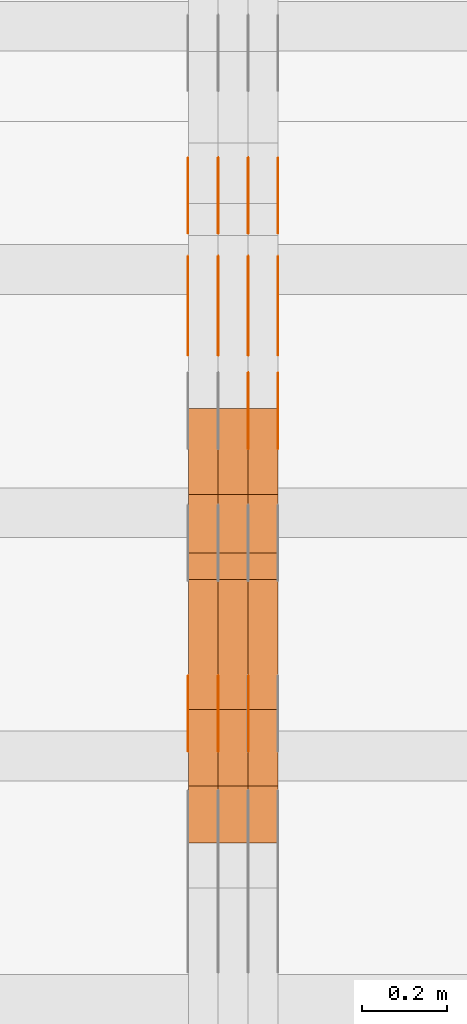
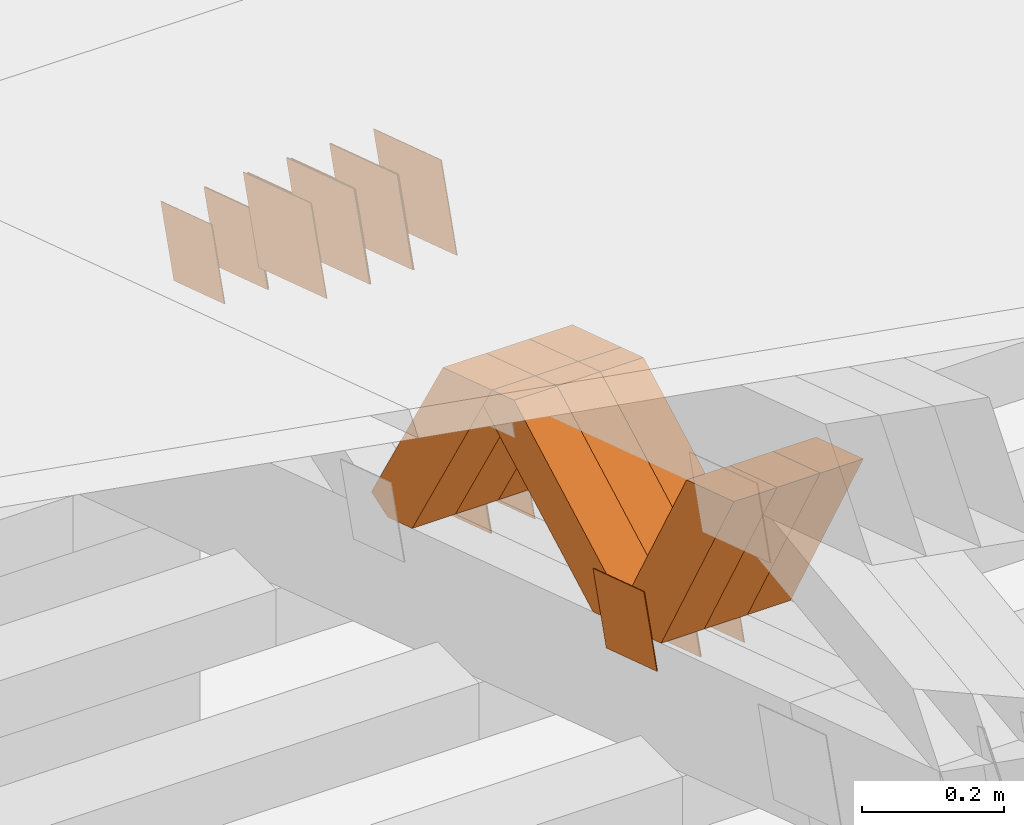
# One storey, part 194 of 385: 28 proxies.
"""IFC2X3 building model written with IfcOpenShell, lengths in millimetres."""

from ifc_helpers import new_model, entity, si_unit, converted_unit, derived_unit, direction, frame, origin, place, context, subcontext, project, spatial, polyline, outline, extrude, source, transform, mapped, material, type_object, type_shapes, element, save


model = new_model("IFC2X3")

# Units and contexts
model_context = context("Model", 3, precision=0.01, world=origin(), true_north=direction((6.12303176911189e-17, 1.0)))
body_context = subcontext(model_context, "Body", "Model", "MODEL_VIEW")
ifc_project = project(units=[si_unit("LENGTHUNIT", "METRE", prefix="MILLI"), si_unit("AREAUNIT", "SQUARE_METRE"), si_unit("VOLUMEUNIT", "CUBIC_METRE"), converted_unit("PLANEANGLEUNIT", "DEGREE", entity("IfcRatioMeasure", 0.0174532925199433), si_unit("PLANEANGLEUNIT", "RADIAN"), dimensions=[0, 0, 0, 0, 0, 0, 0]), si_unit("MASSUNIT", "GRAM", prefix="KILO"), derived_unit("MASSDENSITYUNIT", [(si_unit("MASSUNIT", "GRAM", prefix="KILO"), 1), (si_unit("LENGTHUNIT", "METRE"), -3)]), si_unit("TIMEUNIT", "SECOND"), si_unit("FREQUENCYUNIT", "HERTZ"), si_unit("THERMODYNAMICTEMPERATUREUNIT", "DEGREE_CELSIUS"), derived_unit("THERMALTRANSMITTANCEUNIT", [(si_unit("MASSUNIT", "GRAM", prefix="KILO"), 1), (si_unit("THERMODYNAMICTEMPERATUREUNIT", "KELVIN"), -1), (si_unit("TIMEUNIT", "SECOND"), -3)]), derived_unit("VOLUMETRICFLOWRATEUNIT", [(si_unit("LENGTHUNIT", "METRE"), 3), (si_unit("TIMEUNIT", "SECOND"), -1)]), si_unit("ELECTRICCURRENTUNIT", "AMPERE"), si_unit("ELECTRICVOLTAGEUNIT", "VOLT"), si_unit("POWERUNIT", "WATT"), si_unit("FORCEUNIT", "NEWTON", prefix="KILO"), si_unit("ILLUMINANCEUNIT", "LUX"), si_unit("LUMINOUSFLUXUNIT", "LUMEN"), si_unit("LUMINOUSINTENSITYUNIT", "CANDELA"), derived_unit("USERDEFINED", [(si_unit("MASSUNIT", "GRAM", prefix="KILO"), -1), (si_unit("LENGTHUNIT", "METRE"), -2), (si_unit("TIMEUNIT", "SECOND"), 3), (si_unit("LUMINOUSFLUXUNIT", "LUMEN"), 1)]), derived_unit("LINEARVELOCITYUNIT", [(si_unit("LENGTHUNIT", "METRE"), 1), (si_unit("TIMEUNIT", "SECOND"), -1)]), si_unit("PRESSUREUNIT", "PASCAL"), derived_unit("USERDEFINED", [(si_unit("LENGTHUNIT", "METRE"), -2), (si_unit("MASSUNIT", "GRAM", prefix="KILO"), 1), (si_unit("TIMEUNIT", "SECOND"), -2)])], contexts=[model_context])

# Site, building, storey
site_placement = place(None, origin())
site = spatial("IfcSite", under=ifc_project, at=site_placement, CompositionType="ELEMENT")
building_placement = place(site_placement, origin())
building = spatial("IfcBuilding", under=site, at=building_placement, CompositionType="ELEMENT")
storey_placement = place(building_placement, origin())
storey = spatial("IfcBuildingStorey", under=building, at=storey_placement, Name="Default", CompositionType="ELEMENT", Elevation=0.0)

# Proxies
ifc_material_1 = material(Name="IfcSurfaceStyle #177786")
building_element_proxy_type_1 = type_object("IfcBuildingElementProxyType", PredefinedType="NOTDEFINED", material=ifc_material_1)
shared_shape_1 = source(origin(), body_context, "Body", "SweptSolid", [
    extrude(outline(polyline([(-74.9998605591059, -59.9999264677526), (74.999875428623, -59.9999264677526), (74.9998605591068, 59.9999264677526), (-74.9998754286239, 59.9999264677526), (-74.9998605591059, -59.9999264677526)])), frame((75.0000889884782, 60.0000460315623, 0.0), z_axis=(0.0, 0.0, 1.0), x_axis=(-1.0, 0.0, 0.0)), (0.0, 0.0, 1.0), 1.3),
])
type_shapes(building_element_proxy_type_1, [shared_shape_1])
proxy_1_placement = place(building_placement, frame((12386.3, 20621.9679769682, 2241.76551219004), z_axis=(-1.0, 0.0, 0.0), x_axis=(0.0, -0.951056516295154, 0.309016994374948)))
element("IfcBuildingElementProxy", 1, at=proxy_1_placement, inside=storey, type_object=building_element_proxy_type_1, material=ifc_material_1, context=body_context, shape_type="MappedRepresentation", body=[
    mapped(shared_shape_1, transform((0.0, 0.0, 0.0), scale=1.0)),
])
ifc_material_2 = material(Name="IfcSurfaceStyle #177729")
building_element_proxy_type_2 = type_object("IfcBuildingElementProxyType", PredefinedType="NOTDEFINED", material=ifc_material_2)
shared_shape_2 = source(origin(), body_context, "Body", "SweptSolid", [
    extrude(outline(polyline([(-74.9998605591059, -59.9999264677526), (74.999875428623, -59.9999264677526), (74.9998605591068, 59.9999264677526), (-74.9998754286239, 59.9999264677526), (-74.9998605591059, -59.9999264677526)])), frame((75.0000889884782, 60.0000460315623, 0.0), z_axis=(0.0, 0.0, 1.0), x_axis=(-1.0, 0.0, 0.0)), (0.0, 0.0, 1.0), 1.3),
])
type_shapes(building_element_proxy_type_2, [shared_shape_2])
proxy_2_placement = place(building_placement, frame((12315.0, 20621.9679769682, 2241.76551219004), z_axis=(-1.0, 0.0, 0.0), x_axis=(0.0, -0.951056516295154, 0.309016994374948)))
element("IfcBuildingElementProxy", 2, at=proxy_2_placement, inside=storey, type_object=building_element_proxy_type_2, material=ifc_material_2, context=body_context, shape_type="MappedRepresentation", body=[
    mapped(shared_shape_2, transform((0.0, 0.0, 0.0), scale=1.0)),
])
ifc_material_3 = material(Name="IfcSurfaceStyle #177672")
building_element_proxy_type_3 = type_object("IfcBuildingElementProxyType", PredefinedType="NOTDEFINED", material=ifc_material_3)
shared_shape_3 = source(origin(), body_context, "Body", "SweptSolid", [
    extrude(outline(polyline([(-74.9998605591059, -59.9999264677526), (74.999875428623, -59.9999264677526), (74.9998605591068, 59.9999264677526), (-74.9998754286239, 59.9999264677526), (-74.9998605591059, -59.9999264677526)])), frame((75.0000889884782, 60.0000460315623, 0.0), z_axis=(0.0, 0.0, 1.0), x_axis=(-1.0, 0.0, 0.0)), (0.0, 0.0, 1.0), 1.3),
])
type_shapes(building_element_proxy_type_3, [shared_shape_3])
proxy_3_placement = place(building_placement, frame((12316.3, 20621.9679769682, 2241.76551219004), z_axis=(-1.0, 0.0, 0.0), x_axis=(0.0, -0.951056516295154, 0.309016994374948)))
element("IfcBuildingElementProxy", 3, at=proxy_3_placement, inside=storey, type_object=building_element_proxy_type_3, material=ifc_material_3, context=body_context, shape_type="MappedRepresentation", body=[
    mapped(shared_shape_3, transform((0.0, 0.0, 0.0), scale=1.0)),
])
ifc_material_4 = material(Name="IfcSurfaceStyle #177615")
building_element_proxy_type_4 = type_object("IfcBuildingElementProxyType", PredefinedType="NOTDEFINED", material=ifc_material_4)
shared_shape_4 = source(origin(), body_context, "Body", "SweptSolid", [
    extrude(outline(polyline([(-74.9998605591059, -59.9999264677526), (74.999875428623, -59.9999264677526), (74.9998605591068, 59.9999264677526), (-74.9998754286239, 59.9999264677526), (-74.9998605591059, -59.9999264677526)])), frame((75.0000889884782, 60.0000460315623, 0.0), z_axis=(0.0, 0.0, 1.0), x_axis=(-1.0, 0.0, 0.0)), (0.0, 0.0, 1.0), 1.29999999999999),
])
type_shapes(building_element_proxy_type_4, [shared_shape_4])
proxy_4_placement = place(building_placement, frame((12245.0, 20621.9679769682, 2241.76551219004), z_axis=(-1.0, 0.0, 0.0), x_axis=(0.0, -0.951056516295154, 0.309016994374948)))
element("IfcBuildingElementProxy", 4, at=proxy_4_placement, inside=storey, type_object=building_element_proxy_type_4, material=ifc_material_4, context=body_context, shape_type="MappedRepresentation", body=[
    mapped(shared_shape_4, transform((0.0, 0.0, 0.0), scale=1.0)),
])
ifc_material_5 = material(Name="IfcSurfaceStyle #177558")
building_element_proxy_type_5 = type_object("IfcBuildingElementProxyType", PredefinedType="NOTDEFINED", material=ifc_material_5)
shared_shape_5 = source(origin(), body_context, "Body", "SweptSolid", [
    extrude(outline(polyline([(-74.9998605591059, -59.9999264677526), (74.999875428623, -59.9999264677526), (74.9998605591068, 59.9999264677526), (-74.9998754286239, 59.9999264677526), (-74.9998605591059, -59.9999264677526)])), frame((75.0000889884782, 60.0000460315623, 0.0), z_axis=(0.0, 0.0, 1.0), x_axis=(-1.0, 0.0, 0.0)), (0.0, 0.0, 1.0), 1.29999999999999),
])
type_shapes(building_element_proxy_type_5, [shared_shape_5])
proxy_5_placement = place(building_placement, frame((12246.3, 20621.9679769682, 2241.76551219004), z_axis=(-1.0, 0.0, 0.0), x_axis=(0.0, -0.951056516295154, 0.309016994374948)))
element("IfcBuildingElementProxy", 5, at=proxy_5_placement, inside=storey, type_object=building_element_proxy_type_5, material=ifc_material_5, context=body_context, shape_type="MappedRepresentation", body=[
    mapped(shared_shape_5, transform((0.0, 0.0, 0.0), scale=1.0)),
])
ifc_material_6 = material(Name="IfcSurfaceStyle #177501")
building_element_proxy_type_6 = type_object("IfcBuildingElementProxyType", PredefinedType="NOTDEFINED", material=ifc_material_6)
shared_shape_6 = source(origin(), body_context, "Body", "SweptSolid", [
    extrude(outline(polyline([(-74.9998605591059, -59.9999264677526), (74.999875428623, -59.9999264677526), (74.9998605591068, 59.9999264677526), (-74.9998754286239, 59.9999264677526), (-74.9998605591059, -59.9999264677526)])), frame((75.0000889884782, 60.0000460315623, 0.0), z_axis=(0.0, 0.0, 1.0), x_axis=(-1.0, 0.0, 0.0)), (0.0, 0.0, 1.0), 1.29999999999999),
])
type_shapes(building_element_proxy_type_6, [shared_shape_6])
proxy_6_placement = place(building_placement, frame((12175.0, 20621.9679769682, 2241.76551219004), z_axis=(-1.0, 0.0, 0.0), x_axis=(0.0, -0.951056516295154, 0.309016994374948)))
element("IfcBuildingElementProxy", 6, at=proxy_6_placement, inside=storey, type_object=building_element_proxy_type_6, material=ifc_material_6, context=body_context, shape_type="MappedRepresentation", body=[
    mapped(shared_shape_6, transform((0.0, 0.0, 0.0), scale=1.0)),
])
ifc_material_7 = material(Name="IfcSurfaceStyle #176076")
building_element_proxy_type_7 = type_object("IfcBuildingElementProxyType", PredefinedType="NOTDEFINED", material=ifc_material_7)
shared_shape_7 = source(origin(), body_context, "Body", "SweptSolid", [
    extrude(outline(polyline([(-100.000260677523, -72.0000050220369), (100.000341220114, -72.0000050220369), (99.9997962944585, 72.0000050220369), (-99.9998768370492, 72.0000050220369), (-100.000260677523, -72.0000050220369)])), frame((100.000341220114, 72.0001826453454, 0.0), z_axis=(0.0, 0.0, 1.0), x_axis=(-1.0, 0.0, 0.0)), (0.0, 0.0, 1.0), 1.3),
])
type_shapes(building_element_proxy_type_7, [shared_shape_7])
proxy_7_placement = place(building_placement, frame((12386.3, 20382.8706354426, 2409.35285895246), z_axis=(-1.0, 0.0, 0.0), x_axis=(0.0, -0.951056516295154, 0.309016994374948)))
element("IfcBuildingElementProxy", 7, at=proxy_7_placement, inside=storey, type_object=building_element_proxy_type_7, material=ifc_material_7, context=body_context, shape_type="MappedRepresentation", body=[
    mapped(shared_shape_7, transform((0.0, 0.0, 0.0), scale=1.0)),
])
ifc_material_8 = material(Name="IfcSurfaceStyle #176019")
building_element_proxy_type_8 = type_object("IfcBuildingElementProxyType", PredefinedType="NOTDEFINED", material=ifc_material_8)
shared_shape_8 = source(origin(), body_context, "Body", "SweptSolid", [
    extrude(outline(polyline([(-100.000260677523, -72.0000050220369), (100.000341220114, -72.0000050220369), (99.9997962944585, 72.0000050220369), (-99.9998768370492, 72.0000050220369), (-100.000260677523, -72.0000050220369)])), frame((100.000341220114, 72.0001826453454, 0.0), z_axis=(0.0, 0.0, 1.0), x_axis=(-1.0, 0.0, 0.0)), (0.0, 0.0, 1.0), 1.3),
])
type_shapes(building_element_proxy_type_8, [shared_shape_8])
proxy_8_placement = place(building_placement, frame((12315.0, 20382.8706354426, 2409.35285895246), z_axis=(-1.0, 0.0, 0.0), x_axis=(0.0, -0.951056516295154, 0.309016994374948)))
element("IfcBuildingElementProxy", 8, at=proxy_8_placement, inside=storey, type_object=building_element_proxy_type_8, material=ifc_material_8, context=body_context, shape_type="MappedRepresentation", body=[
    mapped(shared_shape_8, transform((0.0, 0.0, 0.0), scale=1.0)),
])
ifc_material_9 = material(Name="IfcSurfaceStyle #175962")
building_element_proxy_type_9 = type_object("IfcBuildingElementProxyType", PredefinedType="NOTDEFINED", material=ifc_material_9)
shared_shape_9 = source(origin(), body_context, "Body", "SweptSolid", [
    extrude(outline(polyline([(-100.000260677523, -72.0000050220369), (100.000341220114, -72.0000050220369), (99.9997962944585, 72.0000050220369), (-99.9998768370492, 72.0000050220369), (-100.000260677523, -72.0000050220369)])), frame((100.000341220114, 72.0001826453454, 0.0), z_axis=(0.0, 0.0, 1.0), x_axis=(-1.0, 0.0, 0.0)), (0.0, 0.0, 1.0), 1.3),
])
type_shapes(building_element_proxy_type_9, [shared_shape_9])
proxy_9_placement = place(building_placement, frame((12316.3, 20382.8706354426, 2409.35285895246), z_axis=(-1.0, 0.0, 0.0), x_axis=(0.0, -0.951056516295154, 0.309016994374948)))
element("IfcBuildingElementProxy", 9, at=proxy_9_placement, inside=storey, type_object=building_element_proxy_type_9, material=ifc_material_9, context=body_context, shape_type="MappedRepresentation", body=[
    mapped(shared_shape_9, transform((0.0, 0.0, 0.0), scale=1.0)),
])
ifc_material_10 = material(Name="IfcSurfaceStyle #175905")
building_element_proxy_type_10 = type_object("IfcBuildingElementProxyType", PredefinedType="NOTDEFINED", material=ifc_material_10)
shared_shape_10 = source(origin(), body_context, "Body", "SweptSolid", [
    extrude(outline(polyline([(-100.000260677523, -72.0000050220369), (100.000341220114, -72.0000050220369), (99.9997962944585, 72.0000050220369), (-99.9998768370492, 72.0000050220369), (-100.000260677523, -72.0000050220369)])), frame((100.000341220114, 72.0001826453454, 0.0), z_axis=(0.0, 0.0, 1.0), x_axis=(-1.0, 0.0, 0.0)), (0.0, 0.0, 1.0), 1.29999999999998),
])
type_shapes(building_element_proxy_type_10, [shared_shape_10])
proxy_10_placement = place(building_placement, frame((12245.0, 20382.8706354426, 2409.35285895246), z_axis=(-1.0, 0.0, 0.0), x_axis=(0.0, -0.951056516295154, 0.309016994374948)))
element("IfcBuildingElementProxy", 10, at=proxy_10_placement, inside=storey, type_object=building_element_proxy_type_10, material=ifc_material_10, context=body_context, shape_type="MappedRepresentation", body=[
    mapped(shared_shape_10, transform((0.0, 0.0, 0.0), scale=1.0)),
])
ifc_material_11 = material(Name="IfcSurfaceStyle #175848")
building_element_proxy_type_11 = type_object("IfcBuildingElementProxyType", PredefinedType="NOTDEFINED", material=ifc_material_11)
shared_shape_11 = source(origin(), body_context, "Body", "SweptSolid", [
    extrude(outline(polyline([(-100.000260677523, -72.0000050220369), (100.000341220114, -72.0000050220369), (99.9997962944585, 72.0000050220369), (-99.9998768370492, 72.0000050220369), (-100.000260677523, -72.0000050220369)])), frame((100.000341220114, 72.0001826453454, 0.0), z_axis=(0.0, 0.0, 1.0), x_axis=(-1.0, 0.0, 0.0)), (0.0, 0.0, 1.0), 1.29999999999998),
])
type_shapes(building_element_proxy_type_11, [shared_shape_11])
proxy_11_placement = place(building_placement, frame((12246.3, 20382.8706354426, 2409.35285895246), z_axis=(-1.0, 0.0, 0.0), x_axis=(0.0, -0.951056516295154, 0.309016994374948)))
element("IfcBuildingElementProxy", 11, at=proxy_11_placement, inside=storey, type_object=building_element_proxy_type_11, material=ifc_material_11, context=body_context, shape_type="MappedRepresentation", body=[
    mapped(shared_shape_11, transform((0.0, 0.0, 0.0), scale=1.0)),
])
ifc_material_12 = material(Name="IfcSurfaceStyle #175791")
building_element_proxy_type_12 = type_object("IfcBuildingElementProxyType", PredefinedType="NOTDEFINED", material=ifc_material_12)
shared_shape_12 = source(origin(), body_context, "Body", "SweptSolid", [
    extrude(outline(polyline([(-100.000260677523, -72.0000050220369), (100.000341220114, -72.0000050220369), (99.9997962944585, 72.0000050220369), (-99.9998768370492, 72.0000050220369), (-100.000260677523, -72.0000050220369)])), frame((100.000341220114, 72.0001826453454, 0.0), z_axis=(0.0, 0.0, 1.0), x_axis=(-1.0, 0.0, 0.0)), (0.0, 0.0, 1.0), 1.29999999999999),
])
type_shapes(building_element_proxy_type_12, [shared_shape_12])
proxy_12_placement = place(building_placement, frame((12175.0, 20382.8706354426, 2409.35285895246), z_axis=(-1.0, 0.0, 0.0), x_axis=(0.0, -0.951056516295154, 0.309016994374948)))
element("IfcBuildingElementProxy", 12, at=proxy_12_placement, inside=storey, type_object=building_element_proxy_type_12, material=ifc_material_12, context=body_context, shape_type="MappedRepresentation", body=[
    mapped(shared_shape_12, transform((0.0, 0.0, 0.0), scale=1.0)),
])
ifc_material_13 = material(Name="IfcSurfaceStyle #169806")
building_element_proxy_type_13 = type_object("IfcBuildingElementProxyType", PredefinedType="NOTDEFINED", material=ifc_material_13)
shared_shape_13 = source(origin(), body_context, "Body", "SweptSolid", [
    extrude(outline(polyline([(-74.9998605591127, -59.9999264677599), (74.999875428618, -59.9999264677599), (74.9998605591127, 59.9999264677599), (-74.999875428618, 59.9999264677599), (-74.9998605591127, -59.9999264677599)])), frame((75.0002655673825, 60.0000016373433, 0.0), z_axis=(0.0, 0.0, 1.0), x_axis=(-1.0, 0.0, 0.0)), (0.0, 0.0, 1.0), 1.3),
])
type_shapes(building_element_proxy_type_13, [shared_shape_13])
proxy_13_placement = place(building_placement, frame((12316.3, 19407.1136664358, 2348.71056820494), z_axis=(-1.0, 0.0, 0.0), x_axis=(0.0, -0.951056516295124, 0.309016994375039)))
element("IfcBuildingElementProxy", 13, at=proxy_13_placement, inside=storey, type_object=building_element_proxy_type_13, material=ifc_material_13, context=body_context, shape_type="MappedRepresentation", body=[
    mapped(shared_shape_13, transform((0.0, 0.0, 0.0), scale=1.0)),
])
ifc_material_14 = material(Name="IfcSurfaceStyle #169749")
building_element_proxy_type_14 = type_object("IfcBuildingElementProxyType", PredefinedType="NOTDEFINED", material=ifc_material_14)
shared_shape_14 = source(origin(), body_context, "Body", "SweptSolid", [
    extrude(outline(polyline([(-74.9998605591127, -59.9999264677599), (74.999875428618, -59.9999264677599), (74.9998605591127, 59.9999264677599), (-74.999875428618, 59.9999264677599), (-74.9998605591127, -59.9999264677599)])), frame((75.0002655673825, 60.0000016373433, 0.0), z_axis=(0.0, 0.0, 1.0), x_axis=(-1.0, 0.0, 0.0)), (0.0, 0.0, 1.0), 1.29999999999999),
])
type_shapes(building_element_proxy_type_14, [shared_shape_14])
proxy_14_placement = place(building_placement, frame((12245.0, 19407.1136664358, 2348.71056820494), z_axis=(-1.0, 0.0, 0.0), x_axis=(0.0, -0.951056516295124, 0.309016994375039)))
element("IfcBuildingElementProxy", 14, at=proxy_14_placement, inside=storey, type_object=building_element_proxy_type_14, material=ifc_material_14, context=body_context, shape_type="MappedRepresentation", body=[
    mapped(shared_shape_14, transform((0.0, 0.0, 0.0), scale=1.0)),
])
ifc_material_15 = material(Name="IfcSurfaceStyle #169692")
building_element_proxy_type_15 = type_object("IfcBuildingElementProxyType", PredefinedType="NOTDEFINED", material=ifc_material_15)
shared_shape_15 = source(origin(), body_context, "Body", "SweptSolid", [
    extrude(outline(polyline([(-74.9998605591127, -59.9999264677599), (74.999875428618, -59.9999264677599), (74.9998605591127, 59.9999264677599), (-74.999875428618, 59.9999264677599), (-74.9998605591127, -59.9999264677599)])), frame((75.0002655673825, 60.0000016373433, 0.0), z_axis=(0.0, 0.0, 1.0), x_axis=(-1.0, 0.0, 0.0)), (0.0, 0.0, 1.0), 1.29999999999999),
])
type_shapes(building_element_proxy_type_15, [shared_shape_15])
proxy_15_placement = place(building_placement, frame((12246.3, 19407.1136664358, 2348.71056820494), z_axis=(-1.0, 0.0, 0.0), x_axis=(0.0, -0.951056516295124, 0.309016994375039)))
element("IfcBuildingElementProxy", 15, at=proxy_15_placement, inside=storey, type_object=building_element_proxy_type_15, material=ifc_material_15, context=body_context, shape_type="MappedRepresentation", body=[
    mapped(shared_shape_15, transform((0.0, 0.0, 0.0), scale=1.0)),
])
ifc_material_16 = material(Name="IfcSurfaceStyle #169635")
building_element_proxy_type_16 = type_object("IfcBuildingElementProxyType", PredefinedType="NOTDEFINED", material=ifc_material_16)
shared_shape_16 = source(origin(), body_context, "Body", "SweptSolid", [
    extrude(outline(polyline([(-74.9998605591127, -59.9999264677599), (74.999875428618, -59.9999264677599), (74.9998605591127, 59.9999264677599), (-74.999875428618, 59.9999264677599), (-74.9998605591127, -59.9999264677599)])), frame((75.0002655673825, 60.0000016373433, 0.0), z_axis=(0.0, 0.0, 1.0), x_axis=(-1.0, 0.0, 0.0)), (0.0, 0.0, 1.0), 1.29999999999999),
])
type_shapes(building_element_proxy_type_16, [shared_shape_16])
proxy_16_placement = place(building_placement, frame((12175.0, 19407.1136664358, 2348.71056820494), z_axis=(-1.0, 0.0, 0.0), x_axis=(0.0, -0.951056516295124, 0.309016994375039)))
element("IfcBuildingElementProxy", 16, at=proxy_16_placement, inside=storey, type_object=building_element_proxy_type_16, material=ifc_material_16, context=body_context, shape_type="MappedRepresentation", body=[
    mapped(shared_shape_16, transform((0.0, 0.0, 0.0), scale=1.0)),
])
ifc_material_17 = material(Name="IfcSurfaceStyle #169578")
building_element_proxy_type_17 = type_object("IfcBuildingElementProxyType", PredefinedType="NOTDEFINED", material=ifc_material_17)
shared_shape_17 = source(origin(), body_context, "Body", "SweptSolid", [
    extrude(outline(polyline([(-74.9998605591118, -59.9999264677598), (74.9998754286171, -59.9999264677598), (74.9998605591136, 59.9999264677598), (-74.9998754286189, 59.9999264677598), (-74.9998605591118, -59.9999264677598)])), frame((75.0000347664736, 60.0000016373434, 0.0), z_axis=(0.0, 0.0, 1.0), x_axis=(-1.0, 0.0, 0.0)), (0.0, 0.0, 1.0), 1.3),
])
type_shapes(building_element_proxy_type_17, [shared_shape_17])
proxy_17_placement = place(building_placement, frame((12386.3, 20117.0890328685, 2105.40814929196), z_axis=(-1.0, 0.0, 0.0), x_axis=(0.0, -0.951056516295124, 0.309016994375039)))
element("IfcBuildingElementProxy", 17, at=proxy_17_placement, inside=storey, type_object=building_element_proxy_type_17, material=ifc_material_17, context=body_context, shape_type="MappedRepresentation", body=[
    mapped(shared_shape_17, transform((0.0, 0.0, 0.0), scale=1.0)),
])
ifc_material_18 = material(Name="IfcSurfaceStyle #169521")
building_element_proxy_type_18 = type_object("IfcBuildingElementProxyType", PredefinedType="NOTDEFINED", material=ifc_material_18)
shared_shape_18 = source(origin(), body_context, "Body", "SweptSolid", [
    extrude(outline(polyline([(-74.9998605591118, -59.9999264677598), (74.9998754286171, -59.9999264677598), (74.9998605591136, 59.9999264677598), (-74.9998754286189, 59.9999264677598), (-74.9998605591118, -59.9999264677598)])), frame((75.0000347664736, 60.0000016373434, 0.0), z_axis=(0.0, 0.0, 1.0), x_axis=(-1.0, 0.0, 0.0)), (0.0, 0.0, 1.0), 1.3),
])
type_shapes(building_element_proxy_type_18, [shared_shape_18])
proxy_18_placement = place(building_placement, frame((12315.0, 20117.0890328685, 2105.40814929196), z_axis=(-1.0, 0.0, 0.0), x_axis=(0.0, -0.951056516295124, 0.309016994375039)))
element("IfcBuildingElementProxy", 18, at=proxy_18_placement, inside=storey, type_object=building_element_proxy_type_18, material=ifc_material_18, context=body_context, shape_type="MappedRepresentation", body=[
    mapped(shared_shape_18, transform((0.0, 0.0, 0.0), scale=1.0)),
])
ifc_material_19 = material(Name="IfcSurfaceStyle #169464")
building_element_proxy_type_19 = type_object("IfcBuildingElementProxyType", PredefinedType="NOTDEFINED", material=ifc_material_19)
shared_shape_19 = source(origin(), body_context, "Body", "SweptSolid", [
    extrude(outline(polyline([(-74.9998605591118, -59.9999264677598), (74.9998754286171, -59.9999264677598), (74.9998605591136, 59.9999264677598), (-74.9998754286189, 59.9999264677598), (-74.9998605591118, -59.9999264677598)])), frame((75.0000347664736, 60.0000016373434, 0.0), z_axis=(0.0, 0.0, 1.0), x_axis=(-1.0, 0.0, 0.0)), (0.0, 0.0, 1.0), 1.3),
])
type_shapes(building_element_proxy_type_19, [shared_shape_19])
proxy_19_placement = place(building_placement, frame((12316.3, 20117.0890328685, 2105.40814929196), z_axis=(-1.0, 0.0, 0.0), x_axis=(0.0, -0.951056516295124, 0.309016994375039)))
element("IfcBuildingElementProxy", 19, at=proxy_19_placement, inside=storey, type_object=building_element_proxy_type_19, material=ifc_material_19, context=body_context, shape_type="MappedRepresentation", body=[
    mapped(shared_shape_19, transform((0.0, 0.0, 0.0), scale=1.0)),
])
ifc_material_20 = material(Name="IfcSurfaceStyle #153162")
building_element_proxy_type_20 = type_object("IfcBuildingElementProxyType", Name="T1-W40 153160", PredefinedType="NOTDEFINED", material=ifc_material_20)
shared_shape_20 = source(origin(), body_context, "Body", "SweptSolid", [
    extrude(outline(polyline([(-190.697067347251, -47.4992767218045), (178.704677543904, -47.4992767218045), (178.119540532346, -0.000296092407564622), (126.935785980356, 47.4999913795318), (-293.062936709355, 47.4988581564849), (-190.697067347251, -47.4992767218045)])), frame((178.7049897723, 47.4999913795318, 0.0), z_axis=(0.0, 0.0, 1.0), x_axis=(-1.0, 0.0, 0.0)), (0.0, 0.0, 1.0), 70.0),
])
type_shapes(building_element_proxy_type_20, [shared_shape_20])
proxy_20_placement = place(building_placement, frame((12385.0, 19280.269490882, 2403.36730959494), z_axis=(-1.0, 0.0, 0.0), x_axis=(0.0, -0.48691092455798, 0.873451630913866)))
element("IfcBuildingElementProxy", 20, at=proxy_20_placement, inside=storey, type_object=building_element_proxy_type_20, material=ifc_material_20, Name="T1-W40", context=body_context, shape_type="MappedRepresentation", body=[
    mapped(shared_shape_20, transform((0.0, 0.0, 0.0), scale=1.0)),
])
ifc_material_21 = material(Name="IfcSurfaceStyle #153096")
building_element_proxy_type_21 = type_object("IfcBuildingElementProxyType", Name="T1-W40 153094", PredefinedType="NOTDEFINED", material=ifc_material_21)
shared_shape_21 = source(origin(), body_context, "Body", "SweptSolid", [
    extrude(outline(polyline([(-190.697067347251, -47.4992767218045), (178.704677543904, -47.4992767218045), (178.119540532346, -0.000296092407564622), (126.935785980356, 47.4999913795318), (-293.062936709355, 47.4988581564849), (-190.697067347251, -47.4992767218045)])), frame((178.7049897723, 47.4999913795318, 0.0), z_axis=(0.0, 0.0, 1.0), x_axis=(-1.0, 0.0, 0.0)), (0.0, 0.0, 1.0), 70.0),
])
type_shapes(building_element_proxy_type_21, [shared_shape_21])
proxy_21_placement = place(building_placement, frame((12315.0, 19280.269490882, 2403.36730959494), z_axis=(-1.0, 0.0, 0.0), x_axis=(0.0, -0.48691092455798, 0.873451630913866)))
element("IfcBuildingElementProxy", 21, at=proxy_21_placement, inside=storey, type_object=building_element_proxy_type_21, material=ifc_material_21, Name="T1-W40", context=body_context, shape_type="MappedRepresentation", body=[
    mapped(shared_shape_21, transform((0.0, 0.0, 0.0), scale=1.0)),
])
ifc_material_22 = material(Name="IfcSurfaceStyle #153030")
building_element_proxy_type_22 = type_object("IfcBuildingElementProxyType", Name="T1-W40 153028", PredefinedType="NOTDEFINED", material=ifc_material_22)
shared_shape_22 = source(origin(), body_context, "Body", "SweptSolid", [
    extrude(outline(polyline([(-190.697067347251, -47.4992767218045), (178.704677543904, -47.4992767218045), (178.119540532346, -0.000296092407564622), (126.935785980356, 47.4999913795318), (-293.062936709355, 47.4988581564849), (-190.697067347251, -47.4992767218045)])), frame((178.7049897723, 47.4999913795318, 0.0), z_axis=(0.0, 0.0, 1.0), x_axis=(-1.0, 0.0, 0.0)), (0.0, 0.0, 1.0), 70.0),
])
type_shapes(building_element_proxy_type_22, [shared_shape_22])
proxy_22_placement = place(building_placement, frame((12245.0, 19280.269490882, 2403.36730959494), z_axis=(-1.0, 0.0, 0.0), x_axis=(0.0, -0.48691092455798, 0.873451630913866)))
element("IfcBuildingElementProxy", 22, at=proxy_22_placement, inside=storey, type_object=building_element_proxy_type_22, material=ifc_material_22, Name="T1-W40", context=body_context, shape_type="MappedRepresentation", body=[
    mapped(shared_shape_22, transform((0.0, 0.0, 0.0), scale=1.0)),
])
ifc_material_23 = material(Name="IfcSurfaceStyle #152766")
building_element_proxy_type_23 = type_object("IfcBuildingElementProxyType", Name="T1-W47 152764", PredefinedType="NOTDEFINED", material=ifc_material_23)
shared_shape_23 = source(origin(), body_context, "Body", "SweptSolid", [
    extrude(outline(polyline([(-273.154581805017, -47.5000119135351), (121.157675769026, -47.5000119135351), (166.341960897813, -0.000128144957132403), (168.441931699108, 47.5000759860137), (-182.78698656093, 47.5000759860137), (-273.154581805017, -47.5000119135351)])), frame((168.441931699108, 47.5000759860137, 0.0), z_axis=(0.0, 0.0, 1.0), x_axis=(-1.0, 0.0, 0.0)), (0.0, 0.0, 1.0), 70.0),
])
type_shapes(building_element_proxy_type_23, [shared_shape_23])
proxy_23_placement = place(building_placement, frame((12385.0, 19755.0380859375, 2553.712890625), z_axis=(-1.0, 0.0, 0.0), x_axis=(0.0, -0.879386813332609, -0.476108005117242)))
element("IfcBuildingElementProxy", 23, at=proxy_23_placement, inside=storey, type_object=building_element_proxy_type_23, material=ifc_material_23, Name="T1-W47", context=body_context, shape_type="MappedRepresentation", body=[
    mapped(shared_shape_23, transform((0.0, 0.0, 0.0), scale=1.0)),
])
ifc_material_24 = material(Name="IfcSurfaceStyle #152700")
building_element_proxy_type_24 = type_object("IfcBuildingElementProxyType", Name="T1-W47 152698", PredefinedType="NOTDEFINED", material=ifc_material_24)
shared_shape_24 = source(origin(), body_context, "Body", "SweptSolid", [
    extrude(outline(polyline([(-273.154581805017, -47.5000119135351), (121.157675769026, -47.5000119135351), (166.341960897813, -0.000128144957132403), (168.441931699108, 47.5000759860137), (-182.78698656093, 47.5000759860137), (-273.154581805017, -47.5000119135351)])), frame((168.441931699108, 47.5000759860137, 0.0), z_axis=(0.0, 0.0, 1.0), x_axis=(-1.0, 0.0, 0.0)), (0.0, 0.0, 1.0), 70.0),
])
type_shapes(building_element_proxy_type_24, [shared_shape_24])
proxy_24_placement = place(building_placement, frame((12315.0, 19755.0380859375, 2553.712890625), z_axis=(-1.0, 0.0, 0.0), x_axis=(0.0, -0.879386813332609, -0.476108005117242)))
element("IfcBuildingElementProxy", 24, at=proxy_24_placement, inside=storey, type_object=building_element_proxy_type_24, material=ifc_material_24, Name="T1-W47", context=body_context, shape_type="MappedRepresentation", body=[
    mapped(shared_shape_24, transform((0.0, 0.0, 0.0), scale=1.0)),
])
ifc_material_25 = material(Name="IfcSurfaceStyle #152634")
building_element_proxy_type_25 = type_object("IfcBuildingElementProxyType", Name="T1-W47 152632", PredefinedType="NOTDEFINED", material=ifc_material_25)
shared_shape_25 = source(origin(), body_context, "Body", "SweptSolid", [
    extrude(outline(polyline([(-273.154581805017, -47.5000119135351), (121.157675769026, -47.5000119135351), (166.341960897813, -0.000128144957132403), (168.441931699108, 47.5000759860137), (-182.78698656093, 47.5000759860137), (-273.154581805017, -47.5000119135351)])), frame((168.441931699108, 47.5000759860137, 0.0), z_axis=(0.0, 0.0, 1.0), x_axis=(-1.0, 0.0, 0.0)), (0.0, 0.0, 1.0), 70.0),
])
type_shapes(building_element_proxy_type_25, [shared_shape_25])
proxy_25_placement = place(building_placement, frame((12245.0, 19755.0380859375, 2553.712890625), z_axis=(-1.0, 0.0, 0.0), x_axis=(0.0, -0.879386813332609, -0.476108005117242)))
element("IfcBuildingElementProxy", 25, at=proxy_25_placement, inside=storey, type_object=building_element_proxy_type_25, material=ifc_material_25, Name="T1-W47", context=body_context, shape_type="MappedRepresentation", body=[
    mapped(shared_shape_25, transform((0.0, 0.0, 0.0), scale=1.0)),
])
ifc_material_26 = material(Name="IfcSurfaceStyle #152370")
building_element_proxy_type_26 = type_object("IfcBuildingElementProxyType", Name="T1-W34 152368", PredefinedType="NOTDEFINED", material=ifc_material_26)
shared_shape_26 = source(origin(), body_context, "Body", "SweptSolid", [
    extrude(outline(polyline([(-197.657161937088, -47.499796538607), (193.17680883218, -47.499796538607), (182.92464491562, -1.98968224184526e-05), (128.354123102956, 47.4998064870182), (-306.798414913668, 47.4998064870182), (-197.657161937088, -47.499796538607)])), frame((193.176852028916, 47.4998566383869, 0.0), z_axis=(0.0, 0.0, 1.0), x_axis=(-1.0, 0.0, 0.0)), (0.0, 0.0, 1.0), 70.0),
])
type_shapes(building_element_proxy_type_26, [shared_shape_26])
proxy_26_placement = place(building_placement, frame((12385.0, 19987.8030409043, 2165.75390635484), z_axis=(-1.0, 0.0, 0.0), x_axis=(0.0, -0.514479403471631, 0.857502736674044)))
element("IfcBuildingElementProxy", 26, at=proxy_26_placement, inside=storey, type_object=building_element_proxy_type_26, material=ifc_material_26, Name="T1-W34", context=body_context, shape_type="MappedRepresentation", body=[
    mapped(shared_shape_26, transform((0.0, 0.0, 0.0), scale=1.0)),
])
ifc_material_27 = material(Name="IfcSurfaceStyle #152304")
building_element_proxy_type_27 = type_object("IfcBuildingElementProxyType", Name="T1-W34 152302", PredefinedType="NOTDEFINED", material=ifc_material_27)
shared_shape_27 = source(origin(), body_context, "Body", "SweptSolid", [
    extrude(outline(polyline([(-197.657161937088, -47.499796538607), (193.17680883218, -47.499796538607), (182.92464491562, -1.98968224184526e-05), (128.354123102956, 47.4998064870182), (-306.798414913668, 47.4998064870182), (-197.657161937088, -47.499796538607)])), frame((193.176852028916, 47.4998566383869, 0.0), z_axis=(0.0, 0.0, 1.0), x_axis=(-1.0, 0.0, 0.0)), (0.0, 0.0, 1.0), 70.0),
])
type_shapes(building_element_proxy_type_27, [shared_shape_27])
proxy_27_placement = place(building_placement, frame((12315.0, 19987.8030409043, 2165.75390635484), z_axis=(-1.0, 0.0, 0.0), x_axis=(0.0, -0.514479403471631, 0.857502736674044)))
element("IfcBuildingElementProxy", 27, at=proxy_27_placement, inside=storey, type_object=building_element_proxy_type_27, material=ifc_material_27, Name="T1-W34", context=body_context, shape_type="MappedRepresentation", body=[
    mapped(shared_shape_27, transform((0.0, 0.0, 0.0), scale=1.0)),
])
ifc_material_28 = material(Name="IfcSurfaceStyle #152238")
building_element_proxy_type_28 = type_object("IfcBuildingElementProxyType", Name="T1-W34 152236", PredefinedType="NOTDEFINED", material=ifc_material_28)
shared_shape_28 = source(origin(), body_context, "Body", "SweptSolid", [
    extrude(outline(polyline([(-197.657161937088, -47.499796538607), (193.17680883218, -47.499796538607), (182.92464491562, -1.98968224184526e-05), (128.354123102956, 47.4998064870182), (-306.798414913668, 47.4998064870182), (-197.657161937088, -47.499796538607)])), frame((193.176852028916, 47.4998566383869, 0.0), z_axis=(0.0, 0.0, 1.0), x_axis=(-1.0, 0.0, 0.0)), (0.0, 0.0, 1.0), 70.0),
])
type_shapes(building_element_proxy_type_28, [shared_shape_28])
proxy_28_placement = place(building_placement, frame((12245.0, 19987.8030409043, 2165.75390635484), z_axis=(-1.0, 0.0, 0.0), x_axis=(0.0, -0.514479403471631, 0.857502736674044)))
element("IfcBuildingElementProxy", 28, at=proxy_28_placement, inside=storey, type_object=building_element_proxy_type_28, material=ifc_material_28, Name="T1-W34", context=body_context, shape_type="MappedRepresentation", body=[
    mapped(shared_shape_28, transform((0.0, 0.0, 0.0), scale=1.0)),
])

save(model, "model.ifc")
